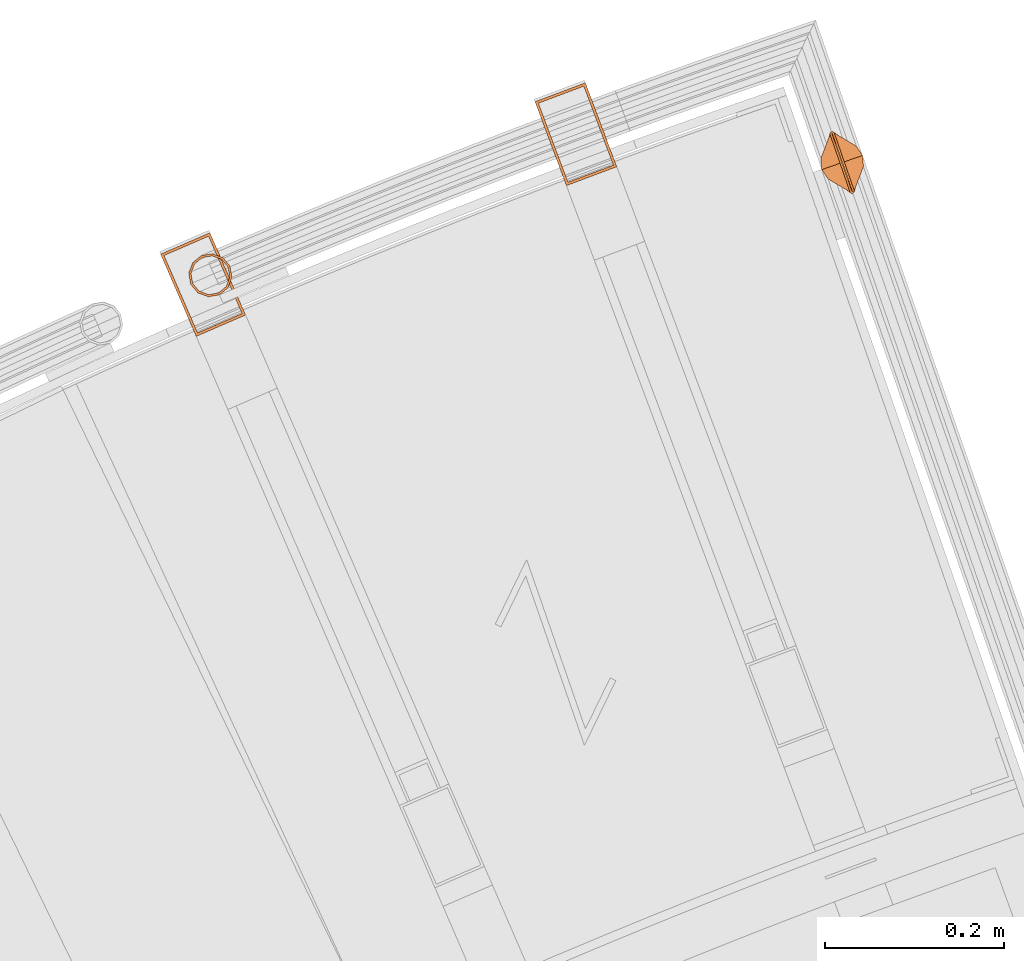
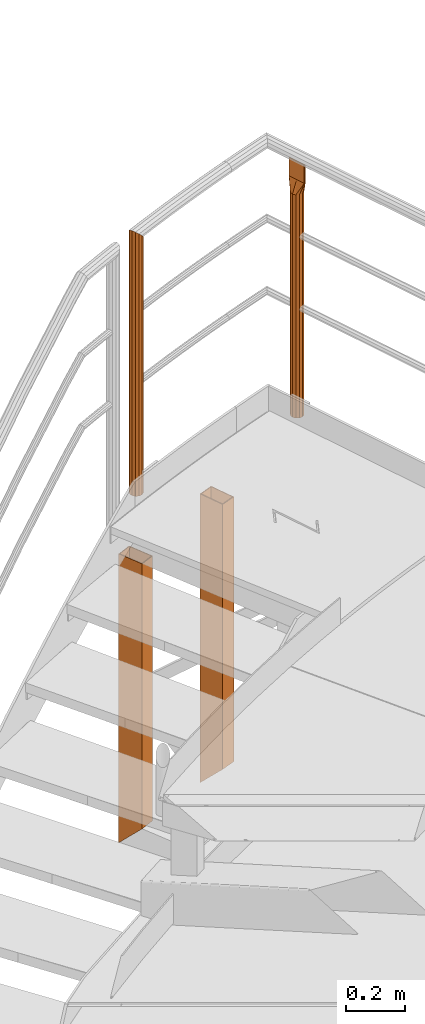
# One storey, part 43 of 126: 4 proxies.
"""IFC2X3 building model written with IfcOpenShell, lengths in millimetres."""

from ifc_helpers import new_model, si_unit, origin, origin_with_axes, place, context, project, spatial, faceted_brep, material, element, save


model = new_model("IFC2X3")

# Units and contexts
context_of_model_1 = context(None, 3, precision=0.1, world=origin())
context_of_model_2 = context(None, 3, precision=0.1, world=origin())
ifc_project = project(units=[si_unit("LENGTHUNIT", "METRE", prefix="MILLI"), si_unit("AREAUNIT", "SQUARE_METRE", prefix="CENTI"), si_unit("VOLUMEUNIT", "CUBIC_METRE", prefix="CENTI"), si_unit("MASSUNIT", "GRAM", prefix="KILO")], contexts=[context_of_model_1, context_of_model_2])

# Site, building, storey
site_placement = place(None, origin_with_axes())
site = spatial("IfcSite", under=ifc_project, at=site_placement, CompositionType="ELEMENT")
building_placement = place(site_placement, origin_with_axes())
building = spatial("IfcBuilding", under=site, at=building_placement, CompositionType="ELEMENT")
storey_placement = place(building_placement, origin_with_axes())
storey = spatial("IfcBuildingStorey", under=building, at=storey_placement, CompositionType="ELEMENT")

# Proxies
ifc_material_1 = material(Name="S235JRG2")
proxy_1_placement = place(storey_placement, origin_with_axes())
element("IfcBuildingElementProxy", 1, at=proxy_1_placement, inside=storey, material=ifc_material_1, context=context_of_model_2, shape_type="Brep", body=[
    faceted_brep([(4855.1856, 16337.239, 10835.15), (4911.3805, 16358.266, 10835.15), (4911.3799, 16358.267, 9635.15), (4855.1851, 16337.24, 9635.15), (4946.4257, 16264.608, 10835.15), (4946.4252, 16264.609, 9735.15), (4890.2309, 16243.581, 10835.15), (4890.2304, 16243.582, 9735.15), (4859.0467, 16335.48, 10835.15), (4891.9893, 16247.442, 10835.15), (4891.9888, 16247.443, 9732.15), (4859.0462, 16335.482, 9638.15), (4942.5646, 16266.366, 10835.15), (4942.5641, 16266.368, 9732.15), (4909.6221, 16354.405, 10835.15), (4909.6215, 16354.406, 9638.15)], [[[0, 1, 2, 3]], [[1, 4, 5, 2]], [[4, 6, 7, 5]], [[0, 3, 7, 6]], [[8, 9, 10, 11]], [[9, 12, 13, 10]], [[12, 14, 15, 13]], [[8, 11, 15, 14]], [[1, 0, 6, 4], [8, 14, 12, 9]], [[3, 2, 5, 7], [10, 13, 15, 11]]]),
])
proxy_2_placement = place(storey_placement, origin_with_axes())
element("IfcBuildingElementProxy", 2, at=proxy_2_placement, inside=storey, material=ifc_material_1, context=context_of_model_2, shape_type="Brep", body=[
    faceted_brep([(4437.667, 16167.21, 10835.15), (4492.726, 16191.053, 10835.15), (4492.7254, 16191.055, 9635.15), (4437.6663, 16167.211, 9635.15), (4532.4648, 16099.288, 10835.15), (4532.4642, 16099.289, 9735.15), (4477.4058, 16075.445, 10835.15), (4477.4052, 16075.446, 9735.15), (4441.6121, 16165.649, 10835.15), (4478.9666, 16079.39, 10835.15), (4478.966, 16079.391, 9732.15), (4441.6115, 16165.65, 9638.15), (4528.5197, 16100.849, 10835.15), (4528.5191, 16100.85, 9732.15), (4491.1652, 16187.108, 10835.15), (4491.1646, 16187.109, 9638.15)], [[[0, 1, 2, 3]], [[1, 4, 5, 2]], [[4, 6, 7, 5]], [[0, 3, 7, 6]], [[8, 9, 10, 11]], [[9, 12, 13, 10]], [[12, 14, 15, 13]], [[8, 11, 15, 14]], [[1, 0, 6, 4], [8, 14, 12, 9]], [[3, 2, 5, 7], [10, 13, 15, 11]]]),
])
proxy_3_placement = place(storey_placement, origin_with_axes())
element("IfcBuildingElementProxy", 3, at=proxy_3_placement, inside=storey, material=ifc_material_1, Name="HANDLAUF", context=context_of_model_2, shape_type="Brep", body=[
    faceted_brep([(4515.1354, 16153.766, 12136.85), (4517.2503, 16141.445, 12140.085), (4517.2503, 16141.445, 11085.15), (4515.1354, 16153.766, 11085.15), (4512.9214, 16129.718, 12148.925), (4512.9214, 16129.718, 11085.15), (4503.3088, 16121.726, 12161.0), (4503.3088, 16121.726, 11085.15), (4490.988, 16119.611, 12173.075), (4490.988, 16119.611, 11085.15), (4479.2605, 16123.94, 12181.915), (4479.2605, 16123.94, 11085.15), (4471.2685, 16133.552, 12185.15), (4471.2685, 16133.552, 11085.15), (4469.1537, 16145.873, 12181.915), (4469.1537, 16145.873, 11085.15), (4473.4825, 16157.601, 12173.075), (4473.4825, 16157.601, 11085.15), (4483.0951, 16165.592, 12161.0), (4483.0951, 16165.592, 11085.15), (4495.4159, 16167.707, 12148.925), (4495.4159, 16167.707, 11085.15), (4507.1435, 16163.379, 12140.085), (4507.1435, 16163.379, 11085.15), (4512.8648, 16152.72, 12139.35), (4505.7002, 16161.337, 12142.251), (4505.7002, 16161.337, 11085.15), (4512.8648, 16152.72, 11085.15), (4495.1867, 16165.218, 12150.175), (4495.1867, 16165.218, 11085.15), (4484.1414, 16163.322, 12161.0), (4484.1414, 16163.322, 11085.15), (4475.5238, 16156.157, 12171.825), (4475.5238, 16156.157, 11085.15), (4471.6431, 16145.644, 12179.75), (4471.6431, 16145.644, 11085.15), (4473.5391, 16134.599, 12182.65), (4473.5391, 16134.599, 11085.15), (4480.7037, 16125.981, 12179.75), (4480.7037, 16125.981, 11085.15), (4491.2172, 16122.1, 12171.825), (4491.2172, 16122.1, 11085.15), (4502.2625, 16123.996, 12161.0), (4502.2625, 16123.996, 11085.15), (4510.8801, 16131.161, 12150.175), (4510.8801, 16131.161, 11085.15), (4514.7608, 16141.674, 12142.251), (4514.7608, 16141.674, 11085.15)], [[[0, 1, 2, 3]], [[1, 4, 5, 2]], [[4, 6, 7, 5]], [[6, 8, 9, 7]], [[8, 10, 11, 9]], [[10, 12, 13, 11]], [[12, 14, 15, 13]], [[14, 16, 17, 15]], [[16, 18, 19, 17]], [[18, 20, 21, 19]], [[20, 22, 23, 21]], [[0, 3, 23, 22]], [[24, 25, 26, 27]], [[25, 28, 29, 26]], [[28, 30, 31, 29]], [[30, 32, 33, 31]], [[32, 34, 35, 33]], [[34, 36, 37, 35]], [[36, 38, 39, 37]], [[38, 40, 41, 39]], [[40, 42, 43, 41]], [[42, 44, 45, 43]], [[44, 46, 47, 45]], [[24, 27, 47, 46]], [[18, 16, 14, 12, 10, 8, 6, 4, 1, 0, 22, 20], [24, 46, 44, 42, 40, 38, 36, 34, 32, 30, 28, 25]], [[19, 21, 23, 3, 2, 5, 7, 9, 11, 13, 15, 17], [26, 29, 31, 33, 35, 37, 39, 41, 43, 45, 47, 27]]]),
])
ifc_material_2 = material(Name="1.4462")
proxy_4_placement = place(storey_placement, origin_with_axes())
element("IfcBuildingElementProxy", 4, at=proxy_4_placement, inside=storey, material=ifc_material_2, Name="Pfosten", context=context_of_model_2, shape_type="Brep", body=[
    faceted_brep([(5205.6379, 16246.536, 12013.55), (5193.1693, 16245.637, 12013.55), (5193.1693, 16245.637, 11086.694), (5205.6379, 16246.536, 11086.693), (5181.9219, 16251.093, 12013.55), (5181.9219, 16251.093, 11086.696), (5174.9094, 16261.442, 12013.55), (5174.9094, 16261.442, 11086.7), (5174.0109, 16273.911, 12013.55), (5174.0109, 16273.911, 11086.704), (5179.467, 16285.158, 12013.55), (5179.467, 16285.158, 11086.706), (5189.8159, 16292.171, 12013.55), (5189.8159, 16292.171, 11086.707), (5202.2845, 16293.069, 12013.55), (5202.2845, 16293.069, 11086.706), (5213.5319, 16287.613, 12013.55), (5213.5319, 16287.613, 11086.704), (5220.5444, 16277.264, 12013.55), (5220.5444, 16277.264, 11086.7), (5221.443, 16264.796, 12013.55), (5221.443, 16264.796, 11086.696), (5215.9868, 16253.548, 12013.55), (5215.9868, 16253.548, 11086.694), (5211.8958, 16285.723, 12013.55), (5201.8127, 16290.614, 12013.55), (5201.8127, 16290.614, 11086.706), (5211.8958, 16285.723, 11086.703), (5190.6348, 16289.808, 12013.55), (5190.6348, 16289.808, 11086.707), (5181.3573, 16283.522, 12013.55), (5181.3573, 16283.522, 11086.706), (5176.4659, 16273.439, 12013.55), (5176.4659, 16273.439, 11086.703), (5177.2715, 16262.261, 12013.55), (5177.2715, 16262.261, 11086.7), (5183.558, 16252.983, 12013.55), (5183.558, 16252.983, 11086.697), (5193.6411, 16248.092, 12013.55), (5193.6411, 16248.092, 11086.694), (5204.819, 16248.898, 12013.55), (5204.819, 16248.898, 11086.693), (5214.0965, 16255.184, 12013.55), (5214.0965, 16255.184, 11086.694), (5218.9879, 16265.267, 12013.55), (5218.9879, 16265.267, 11086.697), (5218.1823, 16276.445, 12013.55), (5218.1823, 16276.445, 11086.7), (5209.6861, 16234.86, 12061.85), (5207.776, 16234.972, 12061.85), (5206.5051, 16236.403, 12061.85), (5195.3648, 16268.534, 12061.85), (5184.2246, 16300.665, 12061.85), (5184.3374, 16302.576, 12061.85), (5185.7677, 16303.846, 12061.85), (5187.6778, 16303.734, 12061.85), (5188.9488, 16302.303, 12061.85), (5200.089, 16270.172, 12061.85), (5211.2292, 16238.041, 12061.85), (5211.1164, 16236.131, 12061.85), (5186.7757, 16301.55, 12061.85), (5186.674, 16301.664, 12061.85), (5186.5212, 16301.673, 12061.85), (5186.4068, 16301.572, 12061.85), (5186.3977, 16301.419, 12061.85), (5197.5379, 16269.288, 12061.85), (5208.6782, 16237.156, 12061.85), (5208.7798, 16237.042, 12061.85), (5208.9326, 16237.033, 12061.85), (5209.0471, 16237.134, 12061.85), (5209.0561, 16237.287, 12061.85), (5197.9159, 16269.419, 12061.85), (5209.6861, 16234.86, 12136.7), (5207.776, 16234.972, 12136.7), (5206.5051, 16236.403, 12136.7), (5195.3648, 16268.534, 12136.7), (5184.2246, 16300.665, 12136.7), (5184.3374, 16302.576, 12136.7), (5185.7677, 16303.846, 12136.7), (5187.6778, 16303.734, 12136.7), (5188.9488, 16302.303, 12136.7), (5200.089, 16270.172, 12136.7), (5211.2292, 16238.041, 12136.7), (5211.1164, 16236.131, 12136.7), (5186.7757, 16301.55, 12136.7), (5186.674, 16301.664, 12136.7), (5186.5212, 16301.673, 12136.7), (5186.4068, 16301.572, 12136.7), (5186.3977, 16301.419, 12136.7), (5197.5379, 16269.288, 12136.7), (5208.6782, 16237.156, 12136.7), (5208.7798, 16237.042, 12136.7), (5208.9326, 16237.033, 12136.7), (5209.0471, 16237.134, 12136.7), (5209.0561, 16237.287, 12136.7), (5197.9159, 16269.419, 12136.7)], [[[0, 1, 2, 3]], [[1, 4, 5, 2]], [[4, 6, 7, 5]], [[6, 8, 9, 7]], [[8, 10, 11, 9]], [[10, 12, 13, 11]], [[12, 14, 15, 13]], [[14, 16, 17, 15]], [[16, 18, 19, 17]], [[18, 20, 21, 19]], [[20, 22, 23, 21]], [[0, 3, 23, 22]], [[24, 25, 26, 27]], [[25, 28, 29, 26]], [[28, 30, 31, 29]], [[30, 32, 33, 31]], [[32, 34, 35, 33]], [[34, 36, 37, 35]], [[36, 38, 39, 37]], [[38, 40, 41, 39]], [[40, 42, 43, 41]], [[42, 44, 45, 43]], [[44, 46, 47, 45]], [[24, 27, 47, 46]], [[0, 48, 49, 1]], [[1, 49, 50, 4]], [[4, 50, 51, 6]], [[6, 51, 52, 8]], [[8, 52, 53, 10]], [[10, 53, 54, 12]], [[12, 54, 55, 14]], [[14, 55, 56, 16]], [[16, 56, 57, 18]], [[18, 57, 58, 20]], [[20, 58, 59, 22]], [[22, 59, 48, 0]], [[24, 60, 61, 25]], [[25, 61, 62, 28]], [[28, 62, 63, 30]], [[30, 63, 64, 32]], [[32, 64, 65, 34]], [[34, 65, 66, 36]], [[36, 66, 67, 38]], [[38, 67, 68, 40]], [[40, 68, 69, 42]], [[42, 69, 70, 44]], [[44, 70, 71, 46]], [[46, 71, 60, 24]], [[48, 72, 73, 49]], [[49, 73, 74, 50]], [[50, 74, 75, 51]], [[51, 75, 76, 52]], [[52, 76, 77, 53]], [[53, 77, 78, 54]], [[54, 78, 79, 55]], [[55, 79, 80, 56]], [[56, 80, 81, 57]], [[57, 81, 82, 58]], [[58, 82, 83, 59]], [[48, 59, 83, 72]], [[60, 84, 85, 61]], [[61, 85, 86, 62]], [[62, 86, 87, 63]], [[63, 87, 88, 64]], [[64, 88, 89, 65]], [[65, 89, 90, 66]], [[66, 90, 91, 67]], [[67, 91, 92, 68]], [[68, 92, 93, 69]], [[69, 93, 94, 70]], [[70, 94, 95, 71]], [[60, 71, 95, 84]], [[76, 75, 74, 73, 72, 83, 82, 81, 80, 79, 78, 77], [84, 95, 94, 93, 92, 91, 90, 89, 88, 87, 86, 85]], [[7, 9, 11, 13, 15, 17, 19, 21, 23, 3, 2, 5], [26, 29, 31, 33, 35, 37, 39, 41, 43, 45, 47, 27]]]),
])

save(model, "model.ifc")
